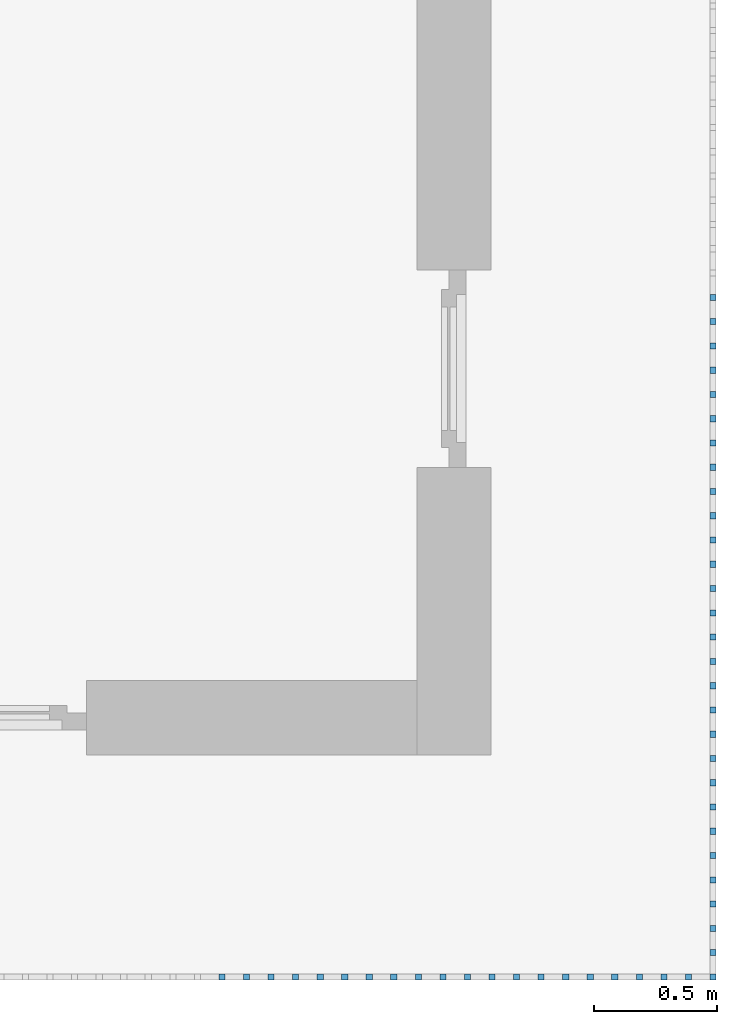
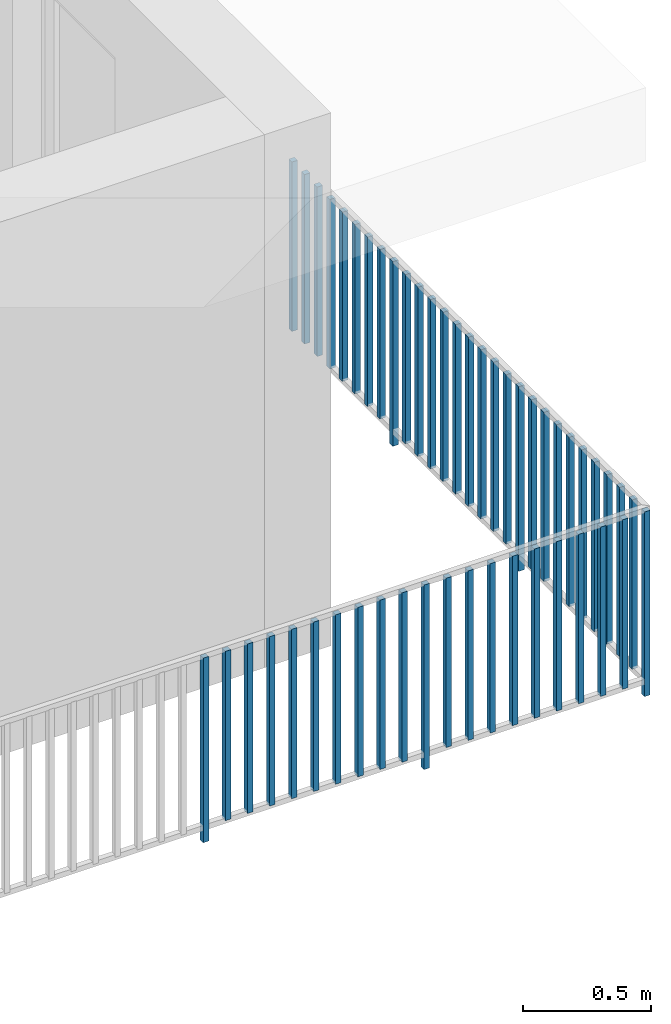
# One storey, part 43 of 54: 49 building element parts, 1 element without a shape of its own.
"""IFC4 building model written with IfcOpenShell, lengths in metres."""

from ifc_helpers import new_model, entity, si_unit, converted_unit, derived_unit, direction, frame, origin_with_axes, place, context, subcontext, project, spatial, polygons, material, type_object, element, aggregate, save


model = new_model("IFC4")

# Units and contexts
model_context = context("Model", 3, precision=1e-05, world=origin_with_axes(), true_north=direction((0.0, 1.0)))
body_context = subcontext(model_context, "Body", "Model", "MODEL_VIEW")
ifc_project = project(units=[si_unit("LENGTHUNIT", "METRE"), si_unit("AREAUNIT", "SQUARE_METRE"), si_unit("VOLUMEUNIT", "CUBIC_METRE"), converted_unit("PLANEANGLEUNIT", "DEGREE", entity("IfcPlaneAngleMeasure", 0.0174532925199), si_unit("PLANEANGLEUNIT", "RADIAN"), dimensions=[0, 0, 0, 0, 0, 0, 0]), converted_unit("TIMEUNIT", "Year", entity("IfcTimeMeasure", 31556926.0), si_unit("TIMEUNIT", "SECOND"), dimensions=[0, 0, 1, 0, 0, 0, 0]), si_unit("MASSUNIT", "GRAM", prefix="KILO"), si_unit("THERMODYNAMICTEMPERATUREUNIT", "DEGREE_CELSIUS"), si_unit("LUMINOUSINTENSITYUNIT", "LUMEN"), si_unit("ENERGYUNIT", "JOULE", prefix="MEGA"), derived_unit("THERMALCONDUCTANCEUNIT", [(si_unit("POWERUNIT", "WATT"), 1), (si_unit("LENGTHUNIT", "METRE"), -1), (si_unit("THERMODYNAMICTEMPERATUREUNIT", "KELVIN"), -1)]), derived_unit("SPECIFICHEATCAPACITYUNIT", [(si_unit("ENERGYUNIT", "JOULE"), 1), (si_unit("MASSUNIT", "GRAM", prefix="KILO"), -1), (si_unit("THERMODYNAMICTEMPERATUREUNIT", "KELVIN"), -1)]), derived_unit("MASSDENSITYUNIT", [(si_unit("MASSUNIT", "GRAM", prefix="KILO"), 1), (si_unit("VOLUMEUNIT", "CUBIC_METRE"), -1)])], contexts=[model_context])

# Site, building, storey, space
site_placement = place(None, origin_with_axes())
site = spatial("IfcSite", under=ifc_project, at=site_placement, CompositionType="ELEMENT")
building_placement = place(site_placement, origin_with_axes())
building = spatial("IfcBuilding", under=site, at=building_placement, CompositionType="ELEMENT")
storey_placement = place(building_placement, frame((0.0, 0.0, 6.29), z_axis=(0.0, 0.0, 1.0), x_axis=(1.0, 0.0, 0.0)))
storey = spatial("IfcBuildingStorey", under=building, at=storey_placement, Name="2. Geschoss", CompositionType="ELEMENT", Elevation=6.29)
space_placement = place(storey_placement, frame((10.2378006196, 9.82118769833, 0.0), z_axis=(0.0, 0.0, 1.0), x_axis=(-1.0, 0.0, 0.0)))
space = spatial("IfcSpace", under=storey, at=space_placement, CompositionType="ELEMENT", PredefinedType="EXTERNAL")

# Railing, building element parts
railing_type = type_object("IfcRailingType", PredefinedType="NOTDEFINED")
railing_placement = place(space_placement, frame((0.0, -7.06315681498e-08, 0.0), z_axis=(0.0, 0.0, 1.0), x_axis=(-1.0, 0.0, 0.0)))
railing = element("IfcRailing", 1, at=railing_placement, inside=space, type_object=railing_type, PredefinedType="NOTDEFINED")
ifc_material = material()
building_element_part_1_placement = place(railing_placement, origin_with_axes())
building_element_part_1 = element("IfcBuildingElementPart", 2, at=building_element_part_1_placement, material=ifc_material, PredefinedType="NOTDEFINED", context=body_context, shape_type="Tessellation", body=[
    polygons([(0.0125, -20.6625, 0.0), (0.0125, -20.6375, 0.0), (0.0125, -20.6375, 0.88), (0.0125, -20.6625, 0.88), (-0.0125, -20.6625, 0.0), (-0.0125, -20.6375, 0.0), (-0.0125, -20.6375, 0.88), (-0.0125, -20.6625, 0.88)], [[[1, 2, 3, 4]], [[1, 5, 6, 2]], [[2, 6, 7, 3]], [[4, 3, 7, 8]], [[5, 1, 4, 8]], [[6, 5, 8, 7]]], closed=True),
])
building_element_part_2_placement = place(railing_placement, origin_with_axes())
building_element_part_2 = element("IfcBuildingElementPart", 3, at=building_element_part_2_placement, material=ifc_material, PredefinedType="NOTDEFINED", context=body_context, shape_type="Tessellation", body=[
    polygons([(-1.97706521739, -20.6625, 0.0), (-1.97706521739, -20.6375, 0.0), (-1.97706521739, -20.6375, 0.88), (-1.97706521739, -20.6625, 0.88), (-2.00206521739, -20.6625, 0.0), (-2.00206521739, -20.6375, 0.0), (-2.00206521739, -20.6375, 0.88), (-2.00206521739, -20.6625, 0.88)], [[[1, 2, 3, 4]], [[1, 5, 6, 2]], [[2, 6, 7, 3]], [[4, 3, 7, 8]], [[5, 1, 4, 8]], [[6, 5, 8, 7]]], closed=True),
])
building_element_part_3_placement = place(railing_placement, origin_with_axes())
building_element_part_3 = element("IfcBuildingElementPart", 4, at=building_element_part_3_placement, material=ifc_material, PredefinedType="NOTDEFINED", context=body_context, shape_type="Tessellation", body=[
    polygons([(-1.87758695652, -20.6625, 0.07), (-1.87758695652, -20.6375, 0.07), (-1.87758695652, -20.6375, 0.8775), (-1.87758695652, -20.6625, 0.8775), (-1.90258695652, -20.6625, 0.07), (-1.90258695652, -20.6375, 0.07), (-1.90258695652, -20.6375, 0.8775), (-1.90258695652, -20.6625, 0.8775)], [[[1, 2, 3, 4]], [[1, 5, 6, 2]], [[2, 6, 7, 3]], [[4, 3, 7, 8]], [[5, 1, 4, 8]], [[6, 5, 8, 7]]], closed=True),
])
building_element_part_4_placement = place(railing_placement, origin_with_axes())
building_element_part_4 = element("IfcBuildingElementPart", 5, at=building_element_part_4_placement, material=ifc_material, PredefinedType="NOTDEFINED", context=body_context, shape_type="Tessellation", body=[
    polygons([(-1.77810869565, -20.6625, 0.07), (-1.77810869565, -20.6375, 0.07), (-1.77810869565, -20.6375, 0.8775), (-1.77810869565, -20.6625, 0.8775), (-1.80310869565, -20.6625, 0.07), (-1.80310869565, -20.6375, 0.07), (-1.80310869565, -20.6375, 0.8775), (-1.80310869565, -20.6625, 0.8775)], [[[1, 2, 3, 4]], [[1, 5, 6, 2]], [[2, 6, 7, 3]], [[4, 3, 7, 8]], [[5, 1, 4, 8]], [[6, 5, 8, 7]]], closed=True),
])
building_element_part_5_placement = place(railing_placement, origin_with_axes())
building_element_part_5 = element("IfcBuildingElementPart", 6, at=building_element_part_5_placement, material=ifc_material, PredefinedType="NOTDEFINED", context=body_context, shape_type="Tessellation", body=[
    polygons([(-1.67863043478, -20.6625, 0.07), (-1.67863043478, -20.6375, 0.07), (-1.67863043478, -20.6375, 0.8775), (-1.67863043478, -20.6625, 0.8775), (-1.70363043478, -20.6625, 0.07), (-1.70363043478, -20.6375, 0.07), (-1.70363043478, -20.6375, 0.8775), (-1.70363043478, -20.6625, 0.8775)], [[[1, 2, 3, 4]], [[1, 5, 6, 2]], [[2, 6, 7, 3]], [[4, 3, 7, 8]], [[5, 1, 4, 8]], [[6, 5, 8, 7]]], closed=True),
])
building_element_part_6_placement = place(railing_placement, origin_with_axes())
building_element_part_6 = element("IfcBuildingElementPart", 7, at=building_element_part_6_placement, material=ifc_material, PredefinedType="NOTDEFINED", context=body_context, shape_type="Tessellation", body=[
    polygons([(-1.57915217391, -20.6625, 0.07), (-1.57915217391, -20.6375, 0.07), (-1.57915217391, -20.6375, 0.8775), (-1.57915217391, -20.6625, 0.8775), (-1.60415217391, -20.6625, 0.07), (-1.60415217391, -20.6375, 0.07), (-1.60415217391, -20.6375, 0.8775), (-1.60415217391, -20.6625, 0.8775)], [[[1, 2, 3, 4]], [[1, 5, 6, 2]], [[2, 6, 7, 3]], [[4, 3, 7, 8]], [[5, 1, 4, 8]], [[6, 5, 8, 7]]], closed=True),
])
building_element_part_7_placement = place(railing_placement, origin_with_axes())
building_element_part_7 = element("IfcBuildingElementPart", 8, at=building_element_part_7_placement, material=ifc_material, PredefinedType="NOTDEFINED", context=body_context, shape_type="Tessellation", body=[
    polygons([(-1.47967391304, -20.6625, 0.07), (-1.47967391304, -20.6375, 0.07), (-1.47967391304, -20.6375, 0.8775), (-1.47967391304, -20.6625, 0.8775), (-1.50467391304, -20.6625, 0.07), (-1.50467391304, -20.6375, 0.07), (-1.50467391304, -20.6375, 0.8775), (-1.50467391304, -20.6625, 0.8775)], [[[1, 2, 3, 4]], [[1, 5, 6, 2]], [[2, 6, 7, 3]], [[4, 3, 7, 8]], [[5, 1, 4, 8]], [[6, 5, 8, 7]]], closed=True),
])
building_element_part_8_placement = place(railing_placement, origin_with_axes())
building_element_part_8 = element("IfcBuildingElementPart", 9, at=building_element_part_8_placement, material=ifc_material, PredefinedType="NOTDEFINED", context=body_context, shape_type="Tessellation", body=[
    polygons([(-1.38019565217, -20.6625, 0.07), (-1.38019565217, -20.6375, 0.07), (-1.38019565217, -20.6375, 0.8775), (-1.38019565217, -20.6625, 0.8775), (-1.40519565217, -20.6625, 0.07), (-1.40519565217, -20.6375, 0.07), (-1.40519565217, -20.6375, 0.8775), (-1.40519565217, -20.6625, 0.8775)], [[[1, 2, 3, 4]], [[1, 5, 6, 2]], [[2, 6, 7, 3]], [[4, 3, 7, 8]], [[5, 1, 4, 8]], [[6, 5, 8, 7]]], closed=True),
])
building_element_part_9_placement = place(railing_placement, origin_with_axes())
building_element_part_9 = element("IfcBuildingElementPart", 10, at=building_element_part_9_placement, material=ifc_material, PredefinedType="NOTDEFINED", context=body_context, shape_type="Tessellation", body=[
    polygons([(-1.2807173913, -20.6625, 0.07), (-1.2807173913, -20.6375, 0.07), (-1.2807173913, -20.6375, 0.8775), (-1.2807173913, -20.6625, 0.8775), (-1.3057173913, -20.6625, 0.07), (-1.3057173913, -20.6375, 0.07), (-1.3057173913, -20.6375, 0.8775), (-1.3057173913, -20.6625, 0.8775)], [[[1, 2, 3, 4]], [[1, 5, 6, 2]], [[2, 6, 7, 3]], [[4, 3, 7, 8]], [[5, 1, 4, 8]], [[6, 5, 8, 7]]], closed=True),
])
building_element_part_10_placement = place(railing_placement, origin_with_axes())
building_element_part_10 = element("IfcBuildingElementPart", 11, at=building_element_part_10_placement, material=ifc_material, PredefinedType="NOTDEFINED", context=body_context, shape_type="Tessellation", body=[
    polygons([(-1.18123913043, -20.6625, 0.07), (-1.18123913043, -20.6375, 0.07), (-1.18123913043, -20.6375, 0.8775), (-1.18123913043, -20.6625, 0.8775), (-1.20623913043, -20.6625, 0.07), (-1.20623913043, -20.6375, 0.07), (-1.20623913043, -20.6375, 0.8775), (-1.20623913043, -20.6625, 0.8775)], [[[1, 2, 3, 4]], [[1, 5, 6, 2]], [[2, 6, 7, 3]], [[4, 3, 7, 8]], [[5, 1, 4, 8]], [[6, 5, 8, 7]]], closed=True),
])
building_element_part_11_placement = place(railing_placement, origin_with_axes())
building_element_part_11 = element("IfcBuildingElementPart", 12, at=building_element_part_11_placement, material=ifc_material, PredefinedType="NOTDEFINED", context=body_context, shape_type="Tessellation", body=[
    polygons([(-1.08176086957, -20.6625, 0.07), (-1.08176086957, -20.6375, 0.07), (-1.08176086957, -20.6375, 0.8775), (-1.08176086957, -20.6625, 0.8775), (-1.10676086957, -20.6625, 0.07), (-1.10676086957, -20.6375, 0.07), (-1.10676086957, -20.6375, 0.8775), (-1.10676086957, -20.6625, 0.8775)], [[[1, 2, 3, 4]], [[1, 5, 6, 2]], [[2, 6, 7, 3]], [[4, 3, 7, 8]], [[5, 1, 4, 8]], [[6, 5, 8, 7]]], closed=True),
])
building_element_part_12_placement = place(railing_placement, origin_with_axes())
building_element_part_12 = element("IfcBuildingElementPart", 13, at=building_element_part_12_placement, material=ifc_material, PredefinedType="NOTDEFINED", context=body_context, shape_type="Tessellation", body=[
    polygons([(-0.982282608696, -20.6625, 0.0), (-0.982282608696, -20.6375, 0.0), (-0.982282608696, -20.6375, 0.88), (-0.982282608696, -20.6625, 0.88), (-1.0072826087, -20.6625, 0.0), (-1.0072826087, -20.6375, 0.0), (-1.0072826087, -20.6375, 0.88), (-1.0072826087, -20.6625, 0.88)], [[[1, 2, 3, 4]], [[1, 5, 6, 2]], [[2, 6, 7, 3]], [[4, 3, 7, 8]], [[5, 1, 4, 8]], [[6, 5, 8, 7]]], closed=True),
])
building_element_part_13_placement = place(railing_placement, origin_with_axes())
building_element_part_13 = element("IfcBuildingElementPart", 14, at=building_element_part_13_placement, material=ifc_material, PredefinedType="NOTDEFINED", context=body_context, shape_type="Tessellation", body=[
    polygons([(-0.882804347826, -20.6625, 0.07), (-0.882804347826, -20.6375, 0.07), (-0.882804347826, -20.6375, 0.8775), (-0.882804347826, -20.6625, 0.8775), (-0.907804347826, -20.6625, 0.07), (-0.907804347826, -20.6375, 0.07), (-0.907804347826, -20.6375, 0.8775), (-0.907804347826, -20.6625, 0.8775)], [[[1, 2, 3, 4]], [[1, 5, 6, 2]], [[2, 6, 7, 3]], [[4, 3, 7, 8]], [[5, 1, 4, 8]], [[6, 5, 8, 7]]], closed=True),
])
building_element_part_14_placement = place(railing_placement, origin_with_axes())
building_element_part_14 = element("IfcBuildingElementPart", 15, at=building_element_part_14_placement, material=ifc_material, PredefinedType="NOTDEFINED", context=body_context, shape_type="Tessellation", body=[
    polygons([(-0.783326086957, -20.6625, 0.07), (-0.783326086957, -20.6375, 0.07), (-0.783326086957, -20.6375, 0.8775), (-0.783326086957, -20.6625, 0.8775), (-0.808326086957, -20.6625, 0.07), (-0.808326086957, -20.6375, 0.07), (-0.808326086957, -20.6375, 0.8775), (-0.808326086957, -20.6625, 0.8775)], [[[1, 2, 3, 4]], [[1, 5, 6, 2]], [[2, 6, 7, 3]], [[4, 3, 7, 8]], [[5, 1, 4, 8]], [[6, 5, 8, 7]]], closed=True),
])
building_element_part_15_placement = place(railing_placement, origin_with_axes())
building_element_part_15 = element("IfcBuildingElementPart", 16, at=building_element_part_15_placement, material=ifc_material, PredefinedType="NOTDEFINED", context=body_context, shape_type="Tessellation", body=[
    polygons([(-0.683847826087, -20.6625, 0.07), (-0.683847826087, -20.6375, 0.07), (-0.683847826087, -20.6375, 0.8775), (-0.683847826087, -20.6625, 0.8775), (-0.708847826087, -20.6625, 0.07), (-0.708847826087, -20.6375, 0.07), (-0.708847826087, -20.6375, 0.8775), (-0.708847826087, -20.6625, 0.8775)], [[[1, 2, 3, 4]], [[1, 5, 6, 2]], [[2, 6, 7, 3]], [[4, 3, 7, 8]], [[5, 1, 4, 8]], [[6, 5, 8, 7]]], closed=True),
])
building_element_part_16_placement = place(railing_placement, origin_with_axes())
building_element_part_16 = element("IfcBuildingElementPart", 17, at=building_element_part_16_placement, material=ifc_material, PredefinedType="NOTDEFINED", context=body_context, shape_type="Tessellation", body=[
    polygons([(-0.584369565217, -20.6625, 0.07), (-0.584369565217, -20.6375, 0.07), (-0.584369565217, -20.6375, 0.8775), (-0.584369565217, -20.6625, 0.8775), (-0.609369565217, -20.6625, 0.07), (-0.609369565217, -20.6375, 0.07), (-0.609369565217, -20.6375, 0.8775), (-0.609369565217, -20.6625, 0.8775)], [[[1, 2, 3, 4]], [[1, 5, 6, 2]], [[2, 6, 7, 3]], [[4, 3, 7, 8]], [[5, 1, 4, 8]], [[6, 5, 8, 7]]], closed=True),
])
building_element_part_17_placement = place(railing_placement, origin_with_axes())
building_element_part_17 = element("IfcBuildingElementPart", 18, at=building_element_part_17_placement, material=ifc_material, PredefinedType="NOTDEFINED", context=body_context, shape_type="Tessellation", body=[
    polygons([(-0.484891304348, -20.6625, 0.07), (-0.484891304348, -20.6375, 0.07), (-0.484891304348, -20.6375, 0.8775), (-0.484891304348, -20.6625, 0.8775), (-0.509891304348, -20.6625, 0.07), (-0.509891304348, -20.6375, 0.07), (-0.509891304348, -20.6375, 0.8775), (-0.509891304348, -20.6625, 0.8775)], [[[1, 2, 3, 4]], [[1, 5, 6, 2]], [[2, 6, 7, 3]], [[4, 3, 7, 8]], [[5, 1, 4, 8]], [[6, 5, 8, 7]]], closed=True),
])
building_element_part_18_placement = place(railing_placement, origin_with_axes())
building_element_part_18 = element("IfcBuildingElementPart", 19, at=building_element_part_18_placement, material=ifc_material, PredefinedType="NOTDEFINED", context=body_context, shape_type="Tessellation", body=[
    polygons([(-0.385413043478, -20.6625, 0.07), (-0.385413043478, -20.6375, 0.07), (-0.385413043478, -20.6375, 0.8775), (-0.385413043478, -20.6625, 0.8775), (-0.410413043478, -20.6625, 0.07), (-0.410413043478, -20.6375, 0.07), (-0.410413043478, -20.6375, 0.8775), (-0.410413043478, -20.6625, 0.8775)], [[[1, 2, 3, 4]], [[1, 5, 6, 2]], [[2, 6, 7, 3]], [[4, 3, 7, 8]], [[5, 1, 4, 8]], [[6, 5, 8, 7]]], closed=True),
])
building_element_part_19_placement = place(railing_placement, origin_with_axes())
building_element_part_19 = element("IfcBuildingElementPart", 20, at=building_element_part_19_placement, material=ifc_material, PredefinedType="NOTDEFINED", context=body_context, shape_type="Tessellation", body=[
    polygons([(-0.285934782609, -20.6625, 0.07), (-0.285934782609, -20.6375, 0.07), (-0.285934782609, -20.6375, 0.8775), (-0.285934782609, -20.6625, 0.8775), (-0.310934782609, -20.6625, 0.07), (-0.310934782609, -20.6375, 0.07), (-0.310934782609, -20.6375, 0.8775), (-0.310934782609, -20.6625, 0.8775)], [[[1, 2, 3, 4]], [[1, 5, 6, 2]], [[2, 6, 7, 3]], [[4, 3, 7, 8]], [[5, 1, 4, 8]], [[6, 5, 8, 7]]], closed=True),
])
building_element_part_20_placement = place(railing_placement, origin_with_axes())
building_element_part_20 = element("IfcBuildingElementPart", 21, at=building_element_part_20_placement, material=ifc_material, PredefinedType="NOTDEFINED", context=body_context, shape_type="Tessellation", body=[
    polygons([(-0.186456521739, -20.6625, 0.07), (-0.186456521739, -20.6375, 0.07), (-0.186456521739, -20.6375, 0.8775), (-0.186456521739, -20.6625, 0.8775), (-0.211456521739, -20.6625, 0.07), (-0.211456521739, -20.6375, 0.07), (-0.211456521739, -20.6375, 0.8775), (-0.211456521739, -20.6625, 0.8775)], [[[1, 2, 3, 4]], [[1, 5, 6, 2]], [[2, 6, 7, 3]], [[4, 3, 7, 8]], [[5, 1, 4, 8]], [[6, 5, 8, 7]]], closed=True),
])
building_element_part_21_placement = place(railing_placement, origin_with_axes())
building_element_part_21 = element("IfcBuildingElementPart", 22, at=building_element_part_21_placement, material=ifc_material, PredefinedType="NOTDEFINED", context=body_context, shape_type="Tessellation", body=[
    polygons([(-0.0869782608696, -20.6625, 0.07), (-0.0869782608696, -20.6375, 0.07), (-0.0869782608696, -20.6375, 0.8775), (-0.0869782608696, -20.6625, 0.8775), (-0.11197826087, -20.6625, 0.07), (-0.11197826087, -20.6375, 0.07), (-0.11197826087, -20.6375, 0.8775), (-0.11197826087, -20.6625, 0.8775)], [[[1, 2, 3, 4]], [[1, 5, 6, 2]], [[2, 6, 7, 3]], [[4, 3, 7, 8]], [[5, 1, 4, 8]], [[6, 5, 8, 7]]], closed=True),
])
building_element_part_22_placement = place(railing_placement, origin_with_axes())
building_element_part_22 = element("IfcBuildingElementPart", 23, at=building_element_part_22_placement, material=ifc_material, PredefinedType="NOTDEFINED", context=body_context, shape_type="Tessellation", body=[
    polygons([(0.0125, -20.5391666667, 0.07), (-0.0125, -20.5391666667, 0.07), (-0.0125, -20.5391666667, 0.8775), (0.0125, -20.5391666667, 0.8775), (0.0125, -20.5641666667, 0.07), (-0.0125, -20.5641666667, 0.07), (-0.0125, -20.5641666667, 0.8775), (0.0125, -20.5641666667, 0.8775)], [[[1, 2, 3, 4]], [[1, 5, 6, 2]], [[2, 6, 7, 3]], [[4, 3, 7, 8]], [[5, 1, 4, 8]], [[6, 5, 8, 7]]], closed=True),
])
building_element_part_23_placement = place(railing_placement, origin_with_axes())
building_element_part_23 = element("IfcBuildingElementPart", 24, at=building_element_part_23_placement, material=ifc_material, PredefinedType="NOTDEFINED", context=body_context, shape_type="Tessellation", body=[
    polygons([(0.0125, -20.4408333333, 0.07), (-0.0125, -20.4408333333, 0.07), (-0.0125, -20.4408333333, 0.8775), (0.0125, -20.4408333333, 0.8775), (0.0125, -20.4658333333, 0.07), (-0.0125, -20.4658333333, 0.07), (-0.0125, -20.4658333333, 0.8775), (0.0125, -20.4658333333, 0.8775)], [[[1, 2, 3, 4]], [[1, 5, 6, 2]], [[2, 6, 7, 3]], [[4, 3, 7, 8]], [[5, 1, 4, 8]], [[6, 5, 8, 7]]], closed=True),
])
building_element_part_24_placement = place(railing_placement, origin_with_axes())
building_element_part_24 = element("IfcBuildingElementPart", 25, at=building_element_part_24_placement, material=ifc_material, PredefinedType="NOTDEFINED", context=body_context, shape_type="Tessellation", body=[
    polygons([(0.0125, -20.3425, 0.07), (-0.0125, -20.3425, 0.07), (-0.0125, -20.3425, 0.8775), (0.0125, -20.3425, 0.8775), (0.0125, -20.3675, 0.07), (-0.0125, -20.3675, 0.07), (-0.0125, -20.3675, 0.8775), (0.0125, -20.3675, 0.8775)], [[[1, 2, 3, 4]], [[1, 5, 6, 2]], [[2, 6, 7, 3]], [[4, 3, 7, 8]], [[5, 1, 4, 8]], [[6, 5, 8, 7]]], closed=True),
])
building_element_part_25_placement = place(railing_placement, origin_with_axes())
building_element_part_25 = element("IfcBuildingElementPart", 26, at=building_element_part_25_placement, material=ifc_material, PredefinedType="NOTDEFINED", context=body_context, shape_type="Tessellation", body=[
    polygons([(0.0125, -20.2441666667, 0.07), (-0.0125, -20.2441666667, 0.07), (-0.0125, -20.2441666667, 0.8775), (0.0125, -20.2441666667, 0.8775), (0.0125, -20.2691666667, 0.07), (-0.0125, -20.2691666667, 0.07), (-0.0125, -20.2691666667, 0.8775), (0.0125, -20.2691666667, 0.8775)], [[[1, 2, 3, 4]], [[1, 5, 6, 2]], [[2, 6, 7, 3]], [[4, 3, 7, 8]], [[5, 1, 4, 8]], [[6, 5, 8, 7]]], closed=True),
])
building_element_part_26_placement = place(railing_placement, origin_with_axes())
building_element_part_26 = element("IfcBuildingElementPart", 27, at=building_element_part_26_placement, material=ifc_material, PredefinedType="NOTDEFINED", context=body_context, shape_type="Tessellation", body=[
    polygons([(0.0125, -20.1458333333, 0.07), (-0.0125, -20.1458333333, 0.07), (-0.0125, -20.1458333333, 0.8775), (0.0125, -20.1458333333, 0.8775), (0.0125, -20.1708333333, 0.07), (-0.0125, -20.1708333333, 0.07), (-0.0125, -20.1708333333, 0.8775), (0.0125, -20.1708333333, 0.8775)], [[[1, 2, 3, 4]], [[1, 5, 6, 2]], [[2, 6, 7, 3]], [[4, 3, 7, 8]], [[5, 1, 4, 8]], [[6, 5, 8, 7]]], closed=True),
])
building_element_part_27_placement = place(railing_placement, origin_with_axes())
building_element_part_27 = element("IfcBuildingElementPart", 28, at=building_element_part_27_placement, material=ifc_material, PredefinedType="NOTDEFINED", context=body_context, shape_type="Tessellation", body=[
    polygons([(0.0125, -20.0475, 0.07), (-0.0125, -20.0475, 0.07), (-0.0125, -20.0475, 0.8775), (0.0125, -20.0475, 0.8775), (0.0125, -20.0725, 0.07), (-0.0125, -20.0725, 0.07), (-0.0125, -20.0725, 0.8775), (0.0125, -20.0725, 0.8775)], [[[1, 2, 3, 4]], [[1, 5, 6, 2]], [[2, 6, 7, 3]], [[4, 3, 7, 8]], [[5, 1, 4, 8]], [[6, 5, 8, 7]]], closed=True),
])
building_element_part_28_placement = place(railing_placement, origin_with_axes())
building_element_part_28 = element("IfcBuildingElementPart", 29, at=building_element_part_28_placement, material=ifc_material, PredefinedType="NOTDEFINED", context=body_context, shape_type="Tessellation", body=[
    polygons([(0.0125, -19.9491666667, 0.07), (-0.0125, -19.9491666667, 0.07), (-0.0125, -19.9491666667, 0.8775), (0.0125, -19.9491666667, 0.8775), (0.0125, -19.9741666667, 0.07), (-0.0125, -19.9741666667, 0.07), (-0.0125, -19.9741666667, 0.8775), (0.0125, -19.9741666667, 0.8775)], [[[1, 2, 3, 4]], [[1, 5, 6, 2]], [[2, 6, 7, 3]], [[4, 3, 7, 8]], [[5, 1, 4, 8]], [[6, 5, 8, 7]]], closed=True),
])
building_element_part_29_placement = place(railing_placement, origin_with_axes())
building_element_part_29 = element("IfcBuildingElementPart", 30, at=building_element_part_29_placement, material=ifc_material, PredefinedType="NOTDEFINED", context=body_context, shape_type="Tessellation", body=[
    polygons([(0.0125, -19.8508333333, 0.07), (-0.0125, -19.8508333333, 0.07), (-0.0125, -19.8508333333, 0.8775), (0.0125, -19.8508333333, 0.8775), (0.0125, -19.8758333333, 0.07), (-0.0125, -19.8758333333, 0.07), (-0.0125, -19.8758333333, 0.8775), (0.0125, -19.8758333333, 0.8775)], [[[1, 2, 3, 4]], [[1, 5, 6, 2]], [[2, 6, 7, 3]], [[4, 3, 7, 8]], [[5, 1, 4, 8]], [[6, 5, 8, 7]]], closed=True),
])
building_element_part_30_placement = place(railing_placement, origin_with_axes())
building_element_part_30 = element("IfcBuildingElementPart", 31, at=building_element_part_30_placement, material=ifc_material, PredefinedType="NOTDEFINED", context=body_context, shape_type="Tessellation", body=[
    polygons([(0.0125, -19.7525, 0.07), (-0.0125, -19.7525, 0.07), (-0.0125, -19.7525, 0.8775), (0.0125, -19.7525, 0.8775), (0.0125, -19.7775, 0.07), (-0.0125, -19.7775, 0.07), (-0.0125, -19.7775, 0.8775), (0.0125, -19.7775, 0.8775)], [[[1, 2, 3, 4]], [[1, 5, 6, 2]], [[2, 6, 7, 3]], [[4, 3, 7, 8]], [[5, 1, 4, 8]], [[6, 5, 8, 7]]], closed=True),
])
building_element_part_31_placement = place(railing_placement, origin_with_axes())
building_element_part_31 = element("IfcBuildingElementPart", 32, at=building_element_part_31_placement, material=ifc_material, PredefinedType="NOTDEFINED", context=body_context, shape_type="Tessellation", body=[
    polygons([(0.0125, -19.6541666667, 0.0), (-0.0125, -19.6541666667, 0.0), (-0.0125, -19.6541666667, 0.88), (0.0125, -19.6541666667, 0.88), (0.0125, -19.6791666667, 0.0), (-0.0125, -19.6791666667, 0.0), (-0.0125, -19.6791666667, 0.88), (0.0125, -19.6791666667, 0.88)], [[[1, 2, 3, 4]], [[1, 5, 6, 2]], [[2, 6, 7, 3]], [[4, 3, 7, 8]], [[5, 1, 4, 8]], [[6, 5, 8, 7]]], closed=True),
])
building_element_part_32_placement = place(railing_placement, origin_with_axes())
building_element_part_32 = element("IfcBuildingElementPart", 33, at=building_element_part_32_placement, material=ifc_material, PredefinedType="NOTDEFINED", context=body_context, shape_type="Tessellation", body=[
    polygons([(0.0125, -19.5558333333, 0.07), (-0.0125, -19.5558333333, 0.07), (-0.0125, -19.5558333333, 0.8775), (0.0125, -19.5558333333, 0.8775), (0.0125, -19.5808333333, 0.07), (-0.0125, -19.5808333333, 0.07), (-0.0125, -19.5808333333, 0.8775), (0.0125, -19.5808333333, 0.8775)], [[[1, 2, 3, 4]], [[1, 5, 6, 2]], [[2, 6, 7, 3]], [[4, 3, 7, 8]], [[5, 1, 4, 8]], [[6, 5, 8, 7]]], closed=True),
])
building_element_part_33_placement = place(railing_placement, origin_with_axes())
building_element_part_33 = element("IfcBuildingElementPart", 34, at=building_element_part_33_placement, material=ifc_material, PredefinedType="NOTDEFINED", context=body_context, shape_type="Tessellation", body=[
    polygons([(0.0125, -19.4575, 0.07), (-0.0125, -19.4575, 0.07), (-0.0125, -19.4575, 0.8775), (0.0125, -19.4575, 0.8775), (0.0125, -19.4825, 0.07), (-0.0125, -19.4825, 0.07), (-0.0125, -19.4825, 0.8775), (0.0125, -19.4825, 0.8775)], [[[1, 2, 3, 4]], [[1, 5, 6, 2]], [[2, 6, 7, 3]], [[4, 3, 7, 8]], [[5, 1, 4, 8]], [[6, 5, 8, 7]]], closed=True),
])
building_element_part_34_placement = place(railing_placement, origin_with_axes())
building_element_part_34 = element("IfcBuildingElementPart", 35, at=building_element_part_34_placement, material=ifc_material, PredefinedType="NOTDEFINED", context=body_context, shape_type="Tessellation", body=[
    polygons([(0.0125, -19.3591666667, 0.07), (-0.0125, -19.3591666667, 0.07), (-0.0125, -19.3591666667, 0.8775), (0.0125, -19.3591666667, 0.8775), (0.0125, -19.3841666667, 0.07), (-0.0125, -19.3841666667, 0.07), (-0.0125, -19.3841666667, 0.8775), (0.0125, -19.3841666667, 0.8775)], [[[1, 2, 3, 4]], [[1, 5, 6, 2]], [[2, 6, 7, 3]], [[4, 3, 7, 8]], [[5, 1, 4, 8]], [[6, 5, 8, 7]]], closed=True),
])
building_element_part_35_placement = place(railing_placement, origin_with_axes())
building_element_part_35 = element("IfcBuildingElementPart", 36, at=building_element_part_35_placement, material=ifc_material, PredefinedType="NOTDEFINED", context=body_context, shape_type="Tessellation", body=[
    polygons([(0.0125, -19.2608333333, 0.07), (-0.0125, -19.2608333333, 0.07), (-0.0125, -19.2608333333, 0.8775), (0.0125, -19.2608333333, 0.8775), (0.0125, -19.2858333333, 0.07), (-0.0125, -19.2858333333, 0.07), (-0.0125, -19.2858333333, 0.8775), (0.0125, -19.2858333333, 0.8775)], [[[1, 2, 3, 4]], [[1, 5, 6, 2]], [[2, 6, 7, 3]], [[4, 3, 7, 8]], [[5, 1, 4, 8]], [[6, 5, 8, 7]]], closed=True),
])
building_element_part_36_placement = place(railing_placement, origin_with_axes())
building_element_part_36 = element("IfcBuildingElementPart", 37, at=building_element_part_36_placement, material=ifc_material, PredefinedType="NOTDEFINED", context=body_context, shape_type="Tessellation", body=[
    polygons([(0.0125, -19.1625, 0.07), (-0.0125, -19.1625, 0.07), (-0.0125, -19.1625, 0.8775), (0.0125, -19.1625, 0.8775), (0.0125, -19.1875, 0.07), (-0.0125, -19.1875, 0.07), (-0.0125, -19.1875, 0.8775), (0.0125, -19.1875, 0.8775)], [[[1, 2, 3, 4]], [[1, 5, 6, 2]], [[2, 6, 7, 3]], [[4, 3, 7, 8]], [[5, 1, 4, 8]], [[6, 5, 8, 7]]], closed=True),
])
building_element_part_37_placement = place(railing_placement, origin_with_axes())
building_element_part_37 = element("IfcBuildingElementPart", 38, at=building_element_part_37_placement, material=ifc_material, PredefinedType="NOTDEFINED", context=body_context, shape_type="Tessellation", body=[
    polygons([(0.0125, -19.0641666667, 0.07), (-0.0125, -19.0641666667, 0.07), (-0.0125, -19.0641666667, 0.8775), (0.0125, -19.0641666667, 0.8775), (0.0125, -19.0891666667, 0.07), (-0.0125, -19.0891666667, 0.07), (-0.0125, -19.0891666667, 0.8775), (0.0125, -19.0891666667, 0.8775)], [[[1, 2, 3, 4]], [[1, 5, 6, 2]], [[2, 6, 7, 3]], [[4, 3, 7, 8]], [[5, 1, 4, 8]], [[6, 5, 8, 7]]], closed=True),
])
building_element_part_38_placement = place(railing_placement, origin_with_axes())
building_element_part_38 = element("IfcBuildingElementPart", 39, at=building_element_part_38_placement, material=ifc_material, PredefinedType="NOTDEFINED", context=body_context, shape_type="Tessellation", body=[
    polygons([(0.0125, -18.9658333333, 0.07), (-0.0125, -18.9658333333, 0.07), (-0.0125, -18.9658333333, 0.8775), (0.0125, -18.9658333333, 0.8775), (0.0125, -18.9908333333, 0.07), (-0.0125, -18.9908333333, 0.07), (-0.0125, -18.9908333333, 0.8775), (0.0125, -18.9908333333, 0.8775)], [[[1, 2, 3, 4]], [[1, 5, 6, 2]], [[2, 6, 7, 3]], [[4, 3, 7, 8]], [[5, 1, 4, 8]], [[6, 5, 8, 7]]], closed=True),
])
building_element_part_39_placement = place(railing_placement, origin_with_axes())
building_element_part_39 = element("IfcBuildingElementPart", 40, at=building_element_part_39_placement, material=ifc_material, PredefinedType="NOTDEFINED", context=body_context, shape_type="Tessellation", body=[
    polygons([(0.0125, -18.8675, 0.07), (-0.0125, -18.8675, 0.07), (-0.0125, -18.8675, 0.8775), (0.0125, -18.8675, 0.8775), (0.0125, -18.8925, 0.07), (-0.0125, -18.8925, 0.07), (-0.0125, -18.8925, 0.8775), (0.0125, -18.8925, 0.8775)], [[[1, 2, 3, 4]], [[1, 5, 6, 2]], [[2, 6, 7, 3]], [[4, 3, 7, 8]], [[5, 1, 4, 8]], [[6, 5, 8, 7]]], closed=True),
])
building_element_part_40_placement = place(railing_placement, origin_with_axes())
building_element_part_40 = element("IfcBuildingElementPart", 41, at=building_element_part_40_placement, material=ifc_material, PredefinedType="NOTDEFINED", context=body_context, shape_type="Tessellation", body=[
    polygons([(0.0125, -18.7691666667, 0.07), (-0.0125, -18.7691666667, 0.07), (-0.0125, -18.7691666667, 0.8775), (0.0125, -18.7691666667, 0.8775), (0.0125, -18.7941666667, 0.07), (-0.0125, -18.7941666667, 0.07), (-0.0125, -18.7941666667, 0.8775), (0.0125, -18.7941666667, 0.8775)], [[[1, 2, 3, 4]], [[1, 5, 6, 2]], [[2, 6, 7, 3]], [[4, 3, 7, 8]], [[5, 1, 4, 8]], [[6, 5, 8, 7]]], closed=True),
])
building_element_part_41_placement = place(railing_placement, origin_with_axes())
building_element_part_41 = element("IfcBuildingElementPart", 42, at=building_element_part_41_placement, material=ifc_material, PredefinedType="NOTDEFINED", context=body_context, shape_type="Tessellation", body=[
    polygons([(0.0125, -18.6708333333, 0.0), (-0.0125, -18.6708333333, 0.0), (-0.0125, -18.6708333333, 0.88), (0.0125, -18.6708333333, 0.88), (0.0125, -18.6958333333, 0.0), (-0.0125, -18.6958333333, 0.0), (-0.0125, -18.6958333333, 0.88), (0.0125, -18.6958333333, 0.88)], [[[1, 2, 3, 4]], [[1, 5, 6, 2]], [[2, 6, 7, 3]], [[4, 3, 7, 8]], [[5, 1, 4, 8]], [[6, 5, 8, 7]]], closed=True),
])
building_element_part_42_placement = place(railing_placement, origin_with_axes())
building_element_part_42 = element("IfcBuildingElementPart", 43, at=building_element_part_42_placement, material=ifc_material, PredefinedType="NOTDEFINED", context=body_context, shape_type="Tessellation", body=[
    polygons([(0.0125, -18.5725, 0.07), (-0.0125, -18.5725, 0.07), (-0.0125, -18.5725, 0.8775), (0.0125, -18.5725, 0.8775), (0.0125, -18.5975, 0.07), (-0.0125, -18.5975, 0.07), (-0.0125, -18.5975, 0.8775), (0.0125, -18.5975, 0.8775)], [[[1, 2, 3, 4]], [[1, 5, 6, 2]], [[2, 6, 7, 3]], [[4, 3, 7, 8]], [[5, 1, 4, 8]], [[6, 5, 8, 7]]], closed=True),
])
building_element_part_43_placement = place(railing_placement, origin_with_axes())
building_element_part_43 = element("IfcBuildingElementPart", 44, at=building_element_part_43_placement, material=ifc_material, PredefinedType="NOTDEFINED", context=body_context, shape_type="Tessellation", body=[
    polygons([(0.0125, -18.4741666667, 0.07), (-0.0125, -18.4741666667, 0.07), (-0.0125, -18.4741666667, 0.8775), (0.0125, -18.4741666667, 0.8775), (0.0125, -18.4991666667, 0.07), (-0.0125, -18.4991666667, 0.07), (-0.0125, -18.4991666667, 0.8775), (0.0125, -18.4991666667, 0.8775)], [[[1, 2, 3, 4]], [[1, 5, 6, 2]], [[2, 6, 7, 3]], [[4, 3, 7, 8]], [[5, 1, 4, 8]], [[6, 5, 8, 7]]], closed=True),
])
building_element_part_44_placement = place(railing_placement, origin_with_axes())
building_element_part_44 = element("IfcBuildingElementPart", 45, at=building_element_part_44_placement, material=ifc_material, PredefinedType="NOTDEFINED", context=body_context, shape_type="Tessellation", body=[
    polygons([(0.0125, -18.3758333333, 0.07), (-0.0125, -18.3758333333, 0.07), (-0.0125, -18.3758333333, 0.8775), (0.0125, -18.3758333333, 0.8775), (0.0125, -18.4008333333, 0.07), (-0.0125, -18.4008333333, 0.07), (-0.0125, -18.4008333333, 0.8775), (0.0125, -18.4008333333, 0.8775)], [[[1, 2, 3, 4]], [[1, 5, 6, 2]], [[2, 6, 7, 3]], [[4, 3, 7, 8]], [[5, 1, 4, 8]], [[6, 5, 8, 7]]], closed=True),
])
building_element_part_45_placement = place(railing_placement, origin_with_axes())
building_element_part_45 = element("IfcBuildingElementPart", 46, at=building_element_part_45_placement, material=ifc_material, PredefinedType="NOTDEFINED", context=body_context, shape_type="Tessellation", body=[
    polygons([(0.0125, -18.2775, 0.07), (-0.0125, -18.2775, 0.07), (-0.0125, -18.2775, 0.8775), (0.0125, -18.2775, 0.8775), (0.0125, -18.3025, 0.07), (-0.0125, -18.3025, 0.07), (-0.0125, -18.3025, 0.8775), (0.0125, -18.3025, 0.8775)], [[[1, 2, 3, 4]], [[1, 5, 6, 2]], [[2, 6, 7, 3]], [[4, 3, 7, 8]], [[5, 1, 4, 8]], [[6, 5, 8, 7]]], closed=True),
])
building_element_part_46_placement = place(railing_placement, origin_with_axes())
building_element_part_46 = element("IfcBuildingElementPart", 47, at=building_element_part_46_placement, material=ifc_material, PredefinedType="NOTDEFINED", context=body_context, shape_type="Tessellation", body=[
    polygons([(0.0125, -18.1791666667, 0.07), (-0.0125, -18.1791666667, 0.07), (-0.0125, -18.1791666667, 0.8775), (0.0125, -18.1791666667, 0.8775), (0.0125, -18.2041666667, 0.07), (-0.0125, -18.2041666667, 0.07), (-0.0125, -18.2041666667, 0.8775), (0.0125, -18.2041666667, 0.8775)], [[[1, 2, 3, 4]], [[1, 5, 6, 2]], [[2, 6, 7, 3]], [[4, 3, 7, 8]], [[5, 1, 4, 8]], [[6, 5, 8, 7]]], closed=True),
])
building_element_part_47_placement = place(railing_placement, origin_with_axes())
building_element_part_47 = element("IfcBuildingElementPart", 48, at=building_element_part_47_placement, material=ifc_material, PredefinedType="NOTDEFINED", context=body_context, shape_type="Tessellation", body=[
    polygons([(0.0125, -18.0808333333, 0.07), (-0.0125, -18.0808333333, 0.07), (-0.0125, -18.0808333333, 0.8775), (0.0125, -18.0808333333, 0.8775), (0.0125, -18.1058333333, 0.07), (-0.0125, -18.1058333333, 0.07), (-0.0125, -18.1058333333, 0.8775), (0.0125, -18.1058333333, 0.8775)], [[[1, 2, 3, 4]], [[1, 5, 6, 2]], [[2, 6, 7, 3]], [[4, 3, 7, 8]], [[5, 1, 4, 8]], [[6, 5, 8, 7]]], closed=True),
])
building_element_part_48_placement = place(railing_placement, origin_with_axes())
building_element_part_48 = element("IfcBuildingElementPart", 49, at=building_element_part_48_placement, material=ifc_material, PredefinedType="NOTDEFINED", context=body_context, shape_type="Tessellation", body=[
    polygons([(0.0125, -17.9825, 0.07), (-0.0125, -17.9825, 0.07), (-0.0125, -17.9825, 0.8775), (0.0125, -17.9825, 0.8775), (0.0125, -18.0075, 0.07), (-0.0125, -18.0075, 0.07), (-0.0125, -18.0075, 0.8775), (0.0125, -18.0075, 0.8775)], [[[1, 2, 3, 4]], [[1, 5, 6, 2]], [[2, 6, 7, 3]], [[4, 3, 7, 8]], [[5, 1, 4, 8]], [[6, 5, 8, 7]]], closed=True),
])
building_element_part_49_placement = place(railing_placement, origin_with_axes())
building_element_part_49 = element("IfcBuildingElementPart", 50, at=building_element_part_49_placement, material=ifc_material, PredefinedType="NOTDEFINED", context=body_context, shape_type="Tessellation", body=[
    polygons([(0.0125, -17.8841666667, 0.07), (-0.0125, -17.8841666667, 0.07), (-0.0125, -17.8841666667, 0.8775), (0.0125, -17.8841666667, 0.8775), (0.0125, -17.9091666667, 0.07), (-0.0125, -17.9091666667, 0.07), (-0.0125, -17.9091666667, 0.8775), (0.0125, -17.9091666667, 0.8775)], [[[1, 2, 3, 4]], [[1, 5, 6, 2]], [[2, 6, 7, 3]], [[4, 3, 7, 8]], [[5, 1, 4, 8]], [[6, 5, 8, 7]]], closed=True),
])
aggregate(railing, [building_element_part_1, building_element_part_2, building_element_part_3, building_element_part_4, building_element_part_5, building_element_part_6, building_element_part_7, building_element_part_8, building_element_part_9, building_element_part_10, building_element_part_11, building_element_part_12, building_element_part_13, building_element_part_14, building_element_part_15, building_element_part_16, building_element_part_17, building_element_part_18, building_element_part_19, building_element_part_20, building_element_part_21, building_element_part_22, building_element_part_23, building_element_part_24, building_element_part_25, building_element_part_26, building_element_part_27, building_element_part_28, building_element_part_29, building_element_part_30, building_element_part_31, building_element_part_32, building_element_part_33, building_element_part_34, building_element_part_35, building_element_part_36, building_element_part_37, building_element_part_38, building_element_part_39, building_element_part_40, building_element_part_41, building_element_part_42, building_element_part_43, building_element_part_44, building_element_part_45, building_element_part_46, building_element_part_47, building_element_part_48, building_element_part_49])

save(model, "model.ifc")
